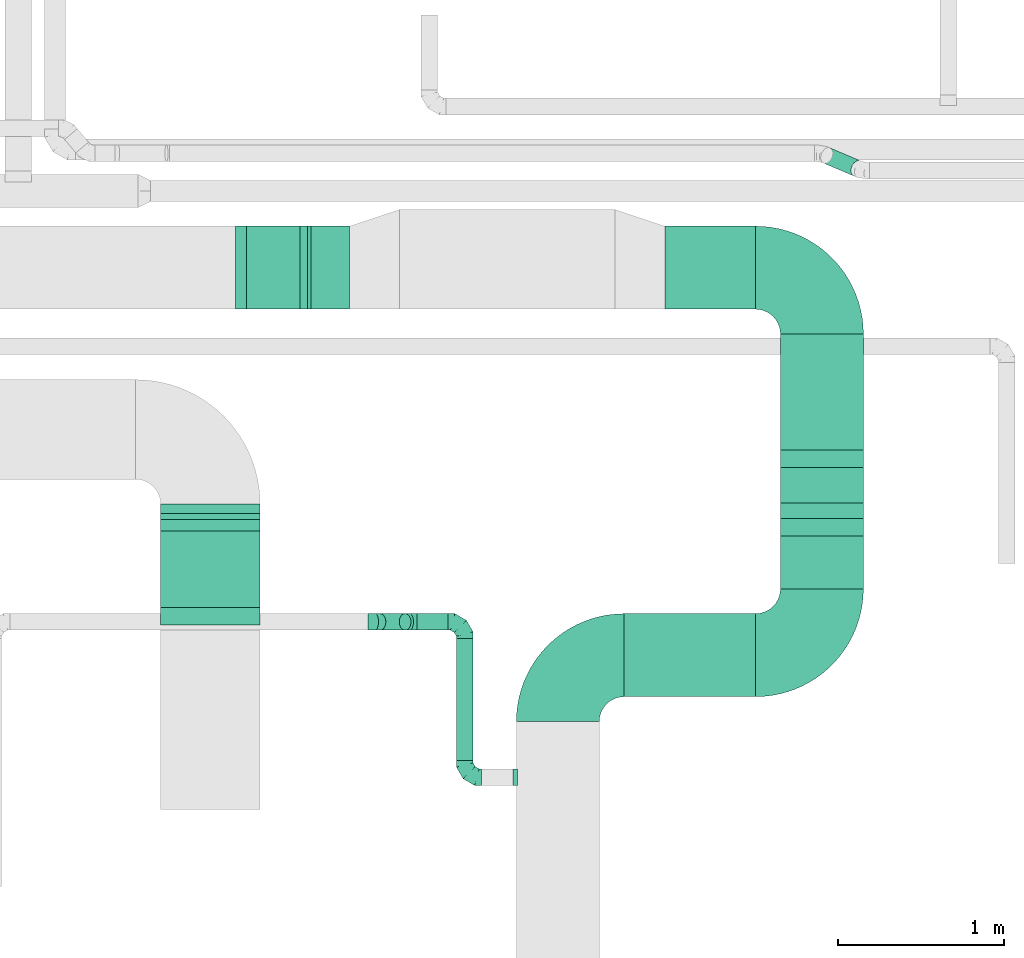
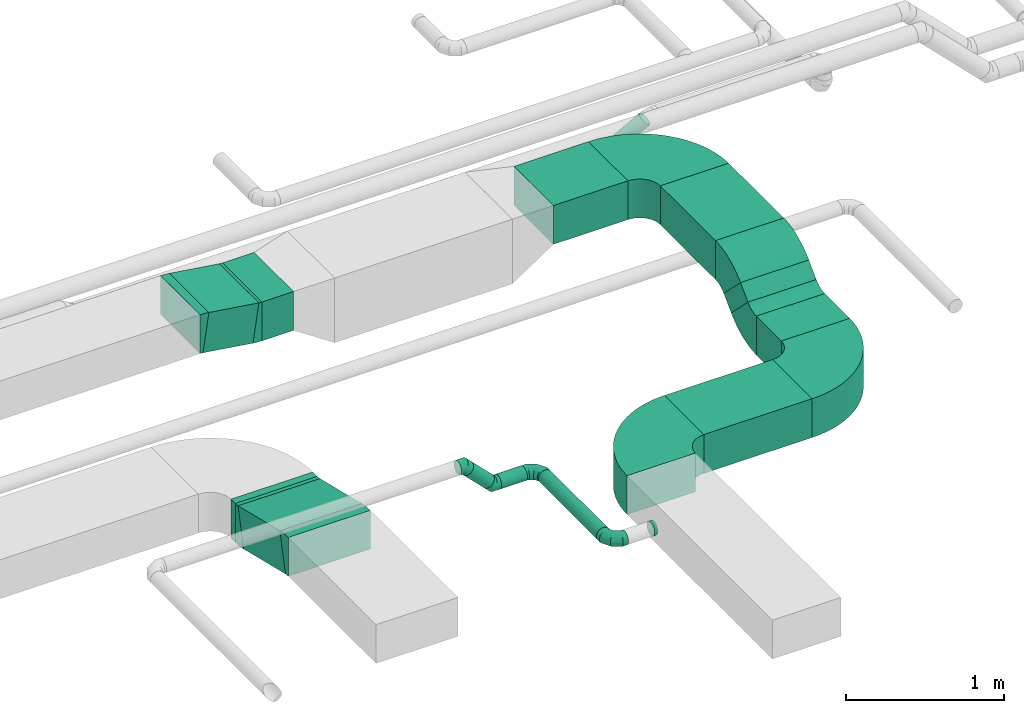
# One storey, part 49 of 60: 14 flow fittings, 13 flow segments.
"""IFC2X3 building model written with IfcOpenShell, lengths in millimetres."""

from ifc_helpers import new_model, entity, si_unit, converted_unit, derived_unit, direction, frame, frame_2d, origin, origin_2d_with_axis, place, context, subcontext, project, spatial, polyline, circle_curve, parameter, trimmed, segment, composite_curve, rectangle, circle, outline, extrude, faceted_brep, source, transform, mapped, material, type_object, type_shapes, element, save


model = new_model("IFC2X3")

# Units and contexts
model_context = context("Model", 3, precision=0.01, world=origin(), true_north=direction((6.12303176911189e-17, 1.0)))
body_context = subcontext(model_context, "Body", "Model", "MODEL_VIEW")
ifc_project = project(units=[si_unit("LENGTHUNIT", "METRE", prefix="MILLI"), si_unit("AREAUNIT", "SQUARE_METRE"), si_unit("VOLUMEUNIT", "CUBIC_METRE"), converted_unit("PLANEANGLEUNIT", "DEGREE", entity("IfcRatioMeasure", 0.0174532925199433), si_unit("PLANEANGLEUNIT", "RADIAN"), dimensions=[0, 0, 0, 0, 0, 0, 0]), si_unit("MASSUNIT", "GRAM", prefix="KILO"), derived_unit("MASSDENSITYUNIT", [(si_unit("MASSUNIT", "GRAM", prefix="KILO"), 1), (si_unit("LENGTHUNIT", "METRE"), -3)]), derived_unit("MOMENTOFINERTIAUNIT", [(si_unit("LENGTHUNIT", "METRE"), 4)]), si_unit("TIMEUNIT", "SECOND"), si_unit("FREQUENCYUNIT", "HERTZ"), si_unit("THERMODYNAMICTEMPERATUREUNIT", "DEGREE_CELSIUS"), derived_unit("THERMALTRANSMITTANCEUNIT", [(si_unit("MASSUNIT", "GRAM", prefix="KILO"), 1), (si_unit("THERMODYNAMICTEMPERATUREUNIT", "KELVIN"), -1), (si_unit("TIMEUNIT", "SECOND"), -3)]), derived_unit("VOLUMETRICFLOWRATEUNIT", [(si_unit("LENGTHUNIT", "METRE"), 3), (si_unit("TIMEUNIT", "SECOND"), -1)]), derived_unit("MASSFLOWRATEUNIT", [(si_unit("MASSUNIT", "GRAM", prefix="KILO"), 1), (si_unit("TIMEUNIT", "SECOND"), -1)]), derived_unit("ROTATIONALFREQUENCYUNIT", [(si_unit("TIMEUNIT", "SECOND"), -1)]), si_unit("ELECTRICCURRENTUNIT", "AMPERE"), si_unit("ELECTRICVOLTAGEUNIT", "VOLT"), si_unit("POWERUNIT", "WATT"), si_unit("FORCEUNIT", "NEWTON", prefix="KILO"), si_unit("ILLUMINANCEUNIT", "LUX"), si_unit("LUMINOUSFLUXUNIT", "LUMEN"), si_unit("LUMINOUSINTENSITYUNIT", "CANDELA"), derived_unit("USERDEFINED", [(si_unit("MASSUNIT", "GRAM", prefix="KILO"), -1), (si_unit("LENGTHUNIT", "METRE"), -2), (si_unit("TIMEUNIT", "SECOND"), 3), (si_unit("LUMINOUSFLUXUNIT", "LUMEN"), 1)]), derived_unit("LINEARVELOCITYUNIT", [(si_unit("LENGTHUNIT", "METRE"), 1), (si_unit("TIMEUNIT", "SECOND"), -1)]), si_unit("PRESSUREUNIT", "PASCAL"), derived_unit("USERDEFINED", [(si_unit("LENGTHUNIT", "METRE"), -2), (si_unit("MASSUNIT", "GRAM", prefix="KILO"), 1), (si_unit("TIMEUNIT", "SECOND"), -2)]), derived_unit("LINEARFORCEUNIT", [(si_unit("MASSUNIT", "GRAM", prefix="KILO"), 1), (si_unit("LENGTHUNIT", "METRE"), 1), (si_unit("TIMEUNIT", "SECOND"), -2), (si_unit("LENGTHUNIT", "METRE"), -1)]), derived_unit("PLANARFORCEUNIT", [(si_unit("MASSUNIT", "GRAM", prefix="KILO"), 1), (si_unit("LENGTHUNIT", "METRE"), 1), (si_unit("TIMEUNIT", "SECOND"), -2), (si_unit("LENGTHUNIT", "METRE"), -2)])], contexts=[model_context])

# Site, building, storey
site_placement = place(None, origin())
site = spatial("IfcSite", under=ifc_project, at=site_placement, CompositionType="ELEMENT")
building_placement = place(site_placement, origin())
building = spatial("IfcBuilding", under=site, at=building_placement, CompositionType="ELEMENT")
storey_placement = place(building_placement, frame((0.0, 0.0, 19800.0)))
storey = spatial("IfcBuildingStorey", under=building, at=storey_placement, CompositionType="ELEMENT", Elevation=19800.0)

# Flow segments
duct_segment_type_1 = type_object("IfcDuctSegmentType", PredefinedType="NOTDEFINED")
flow_segment_1_placement = place(storey_placement, frame((68175.49, 9113.95, 3420.0)))
element("IfcFlowSegment", 1, at=flow_segment_1_placement, inside=storey, type_object=duct_segment_type_1, context=body_context, shape_type="SweptSolid", body=[
    extrude(rectangle(XDim=545.857864376264, YDim=500.0, at=origin_2d_with_axis()), frame((272.93, 250.0, 0.0), z_axis=(0.0, 0.0, 1.0), x_axis=(-1.0, 0.0, 0.0)), (0.0, 0.0, 1.0), 300.000000000001),
])
flow_segment_2_placement = place(storey_placement, frame((67930.49, 6779.81, 3150.0)))
element("IfcFlowSegment", 2, at=flow_segment_2_placement, inside=storey, type_object=duct_segment_type_1, context=body_context, shape_type="SweptSolid", body=[
    extrude(rectangle(XDim=790.857864376312, YDim=500.0, at=origin_2d_with_axis()), frame((395.43, 250.0, 0.0), z_axis=(0.0, 0.0, 1.0), x_axis=(-1.0, 0.0, 0.0)), (0.0, 0.0, 1.0), 300.000000000001),
])
flow_segment_3_placement = place(storey_placement, frame((68871.35, 8265.48, 3420.0)))
element("IfcFlowSegment", 3, at=flow_segment_3_placement, inside=storey, type_object=duct_segment_type_1, context=body_context, shape_type="SweptSolid", body=[
    extrude(rectangle(XDim=698.472628134516, YDim=499.999999999999, at=origin_2d_with_axis()), frame((250.0, 349.24, 0.0), z_axis=(0.0, 0.0, 1.0), x_axis=(0.0, -1.0, 0.0)), (0.0, 0.0, 1.0), 300.000000000001),
])
flow_segment_4_placement = place(storey_placement, frame((68871.35, 7429.81, 3150.0)))
element("IfcFlowSegment", 4, at=flow_segment_4_placement, inside=storey, type_object=duct_segment_type_1, context=body_context, shape_type="SweptSolid", body=[
    extrude(rectangle(XDim=317.141367049098, YDim=499.999999999999, at=origin_2d_with_axis()), frame((250.0, 158.57, 0.0), z_axis=(0.0, 0.0, 1.0), x_axis=(0.0, 1.0, 0.0)), (0.0, 0.0, 1.0), 300.000000000001),
])
flow_segment_5_placement = place(storey_placement, frame((68871.35, 7853.02, 3281.8)))
element("IfcFlowSegment", 5, at=flow_segment_5_placement, inside=storey, type_object=duct_segment_type_1, context=body_context, shape_type="SweptSolid", body=[
    extrude(rectangle(XDim=299.999999999998, YDim=133.309536149783, at=frame_2d((0.0, 0.0), x_axis=(0.0, 1.0))), frame((0.0, 153.2, 153.2), z_axis=(1.0, 0.0, 0.0), x_axis=(0.0, 0.707106792500132, 0.707106769872963)), (0.0, 0.0, 1.0), 500.000000000008),
])
flow_segment_6_placement = place(storey_placement, frame((65137.69, 7246.84, 2937.54)))
element("IfcFlowSegment", 6, at=flow_segment_6_placement, inside=storey, type_object=duct_segment_type_1, context=body_context, shape_type="SweptSolid", body=[
    extrude(rectangle(XDim=300.000000000001, YDim=546.006755026433, at=frame_2d((0.0, 0.0), x_axis=(0.0, 1.0))), frame((0.0, 300.6, 209.93), z_axis=(1.0, 0.0, 0.0), x_axis=(0.0, -0.972018465382417, 0.234904454950542)), (0.0, 0.0, 1.0), 600.000000000002),
])
flow_segment_7_placement = place(storey_placement, frame((66043.25, 9113.95, 3420.0)))
element("IfcFlowSegment", 7, at=flow_segment_7_placement, inside=storey, type_object=duct_segment_type_1, context=body_context, shape_type="SweptSolid", body=[
    extrude(rectangle(XDim=232.243918103055, YDim=500.0, at=origin_2d_with_axis()), frame((116.12, 250.0, 0.0)), (0.0, 0.0, 1.0), 300.000000000001),
])
flow_segment_8_placement = place(storey_placement, frame((65612.18, 9113.95, 3424.76)))
element("IfcFlowSegment", 8, at=flow_segment_8_placement, inside=storey, type_object=duct_segment_type_1, context=body_context, shape_type="SweptSolid", body=[
    extrude(rectangle(XDim=300.000000000003, YDim=369.670729131551, at=frame_2d((0.0, 0.0), x_axis=(0.0, 1.0))), frame((204.65, 0.0, 175.24), z_axis=(0.0, 1.0, 0.0), x_axis=(-0.989413478216875, 0.0, 0.145123978455616)), (0.0, 0.0, 1.0), 500.000000000001),
])
flow_segment_9_placement = place(storey_placement, frame((65137.69, 7883.27, 2924.95)))
element("IfcFlowSegment", 9, at=flow_segment_9_placement, inside=storey, type_object=duct_segment_type_1, context=body_context, shape_type="SweptSolid", body=[
    extrude(rectangle(XDim=56.1804576160397, YDim=600.000000000002, at=origin_2d_with_axis()), frame((300.0, 28.09, 0.0), z_axis=(0.0, 0.0, 1.0), x_axis=(0.0, -1.0, 0.0)), (0.0, 0.0, 1.0), 300.000000000001),
])
duct_segment_type_2 = type_object("IfcDuctSegmentType", PredefinedType="NOTDEFINED")
flow_segment_10_placement = place(storey_placement, frame((66918.4, 6395.17, 3198.4)))
element("IfcFlowSegment", 10, at=flow_segment_10_placement, inside=storey, type_object=duct_segment_type_2, context=body_context, shape_type="SweptSolid", body=[
    extrude(circle(Radius=50.0, at=origin_2d_with_axis()), frame((51.6, 0.0, 51.6), z_axis=(0.0, 1.0, 0.0), x_axis=(1.0, 0.0, 0.0)), (0.0, 0.0, 1.0), 735.000000000014),
])
flow_segment_11_placement = place(storey_placement, frame((66422.34, 7178.57, 3242.34)))
element("IfcFlowSegment", 11, at=flow_segment_11_placement, inside=storey, type_object=duct_segment_type_2, context=body_context, shape_type="SweptSolid", body=[
    extrude(circle(Radius=50.0, at=origin_2d_with_axis()), frame((36.95, 51.6, 188.37), z_axis=(0.707106781186537, 0.0, -0.707106781186558), x_axis=(0.0, -1.0, 0.0)), (0.0, 0.0, 1.0), 214.142135623754),
])
flow_segment_12_placement = place(storey_placement, frame((66681.42, 7178.57, 3198.4)))
element("IfcFlowSegment", 12, at=flow_segment_12_placement, inside=storey, type_object=duct_segment_type_2, context=body_context, shape_type="SweptSolid", body=[
    extrude(circle(Radius=50.0, at=origin_2d_with_axis()), frame((0.0, 51.6, 51.6), z_axis=(1.0, 0.0, 0.0), x_axis=(0.0, 1.0, 0.0)), (0.0, 0.0, 1.0), 188.578643762706),
])
flow_segment_13_placement = place(storey_placement, frame((69112.12, 9912.36, 3249.0)))
element("IfcFlowSegment", 13, at=flow_segment_13_placement, inside=storey, type_object=duct_segment_type_2, context=body_context, shape_type="SweptSolid", body=[
    extrude(circle(Radius=50.0, at=origin_2d_with_axis()), frame((221.32, 49.47, 221.29), z_axis=(-0.677188394410879, 0.287805067624671, -0.677188394410872), x_axis=(0.0, 0.920330918458449, 0.391140640344912)), (0.0, 0.0, 1.0), 270.134206656777),
])

# Flow fittings
ifc_material = material()
duct_fitting_type_1 = type_object("IfcDuctFittingType", PredefinedType="NOTDEFINED", material=ifc_material)
shared_shape_1 = source(origin(), body_context, "Body", "Brep", [
    faceted_brep([(-100.0, 0.0, -50.0), (-100.0, -12.94, -48.3), (-100.0, -25.0, -43.3), (-100.0, -35.36, -35.36), (-100.0, -43.3, -25.0), (-100.0, -48.3, -12.94), (-100.0, -50.0, 0.0), (-100.0, -48.3, 12.94), (-100.0, -43.3, 25.0), (-100.0, -35.36, 35.36), (-100.0, -25.0, 43.3), (-100.0, -12.94, 48.3), (-100.0, 0.0, 50.0), (-100.0, 12.94, 48.3), (-100.0, 25.0, 43.3), (-100.0, 35.36, 35.36), (-100.0, 43.3, 25.0), (-100.0, 48.3, 12.94), (-100.0, 50.0, 0.0), (-100.0, 48.3, -12.94), (-100.0, 43.3, -25.0), (-100.0, 35.36, -35.36), (-100.0, 25.0, -43.3), (-100.0, 12.94, -48.3), (-76.67, 12.94, 48.3), (-79.9, 25.0, 43.3), (-73.21, 0.0, 50.0), (-82.68, 35.36, 35.36), (-86.15, 48.3, 12.94), (-86.6, 50.0, 0.0), (-84.81, 43.3, 25.0), (-84.81, 43.3, -25.0), (-82.68, 35.36, -35.36), (-86.15, 48.3, -12.94), (-76.67, 12.94, -48.3), (-73.21, 0.0, -50.0), (-79.9, 25.0, -43.3), (-69.74, -12.94, -48.3), (-66.51, -25.0, -43.3), (-63.73, -35.36, -35.36), (-61.6, -43.3, -25.0), (-60.26, -48.3, -12.94), (-59.81, -50.0, 0.0), (-60.26, -48.3, 12.94), (-61.6, -43.3, 25.0), (-63.73, -35.36, 35.36), (-66.51, -25.0, 43.3), (-69.74, -12.94, 48.3), (-36.27, 36.27, 48.3), (-45.1, 45.1, 43.3), (-26.79, 26.79, 50.0), (-52.68, 52.68, 35.36), (-58.49, 58.49, 25.0), (-62.15, 62.15, 12.94), (-63.4, 63.4, 0.0), (-62.15, 62.15, -12.94), (-58.49, 58.49, -25.0), (-52.68, 52.68, -35.36), (-36.27, 36.27, -48.3), (-26.79, 26.79, -50.0), (-45.1, 45.1, -43.3), (-17.32, 17.32, -48.3), (-8.49, 8.49, -43.3), (-0.91, 0.91, -35.36), (4.9, -4.9, -25.0), (8.56, -8.56, -12.94), (9.81, -9.81, 0.0), (8.56, -8.56, 12.94), (4.9, -4.9, 25.0), (-0.91, 0.91, 35.36), (-8.49, 8.49, 43.3), (-17.32, 17.32, 48.3), (-12.94, 76.67, 48.3), (-25.0, 79.9, 43.3), (0.0, 73.21, 50.0), (-35.36, 82.68, 35.36), (-43.3, 84.81, 25.0), (-48.3, 86.15, 12.94), (-50.0, 86.6, 0.0), (-48.3, 86.15, -12.94), (-43.3, 84.81, -25.0), (-35.36, 82.68, -35.36), (-12.94, 76.67, -48.3), (0.0, 73.21, -50.0), (-25.0, 79.9, -43.3), (12.94, 69.74, -48.3), (25.0, 66.51, -43.3), (35.36, 63.73, -35.36), (43.3, 61.6, -25.0), (48.3, 60.26, -12.94), (50.0, 59.81, 0.0), (48.3, 60.26, 12.94), (43.3, 61.6, 25.0), (35.36, 63.73, 35.36), (25.0, 66.51, 43.3), (12.94, 69.74, 48.3), (-12.94, 100.0, -48.3), (-25.0, 100.0, -43.3), (-35.36, 100.0, -35.36), (-43.3, 100.0, -25.0), (-48.3, 100.0, -12.94), (-50.0, 100.0, 0.0), (-48.3, 100.0, 12.94), (-43.3, 100.0, 25.0), (-35.36, 100.0, 35.36), (-25.0, 100.0, 43.3), (-12.94, 100.0, 48.3), (0.0, 100.0, 50.0), (12.94, 100.0, 48.3), (25.0, 100.0, 43.3), (35.36, 100.0, 35.36), (43.3, 100.0, 25.0), (48.3, 100.0, 12.94), (50.0, 100.0, 0.0), (48.3, 100.0, -12.94), (43.3, 100.0, -25.0), (35.36, 100.0, -35.36), (25.0, 100.0, -43.3), (12.94, 100.0, -48.3), (0.0, 100.0, -50.0)], [[[0, 1, 2, 3, 4, 5, 6, 7, 8, 9, 10, 11, 12, 13, 14, 15, 16, 17, 18, 19, 20, 21, 22, 23]], [[24, 25, 14, 13]], [[26, 24, 13, 12]], [[14, 25, 27, 15]], [[28, 29, 18, 17]], [[30, 28, 17, 16]], [[15, 27, 30, 16]], [[20, 31, 32, 21]], [[33, 31, 20, 19]], [[18, 29, 33, 19]], [[34, 35, 0, 23]], [[36, 34, 23, 22]], [[32, 36, 22, 21]], [[2, 1, 37, 38]], [[3, 2, 38, 39]], [[0, 35, 37, 1]], [[5, 4, 40, 41]], [[6, 5, 41, 42]], [[3, 39, 40, 4]], [[6, 42, 43, 7]], [[7, 43, 44, 8]], [[8, 44, 45, 9]], [[10, 46, 47, 11]], [[11, 47, 26, 12]], [[10, 9, 45, 46]], [[48, 49, 25, 24]], [[50, 48, 24, 26]], [[27, 25, 49, 51]], [[52, 53, 28, 30]], [[51, 52, 30, 27]], [[29, 28, 53, 54]], [[55, 56, 31, 33]], [[54, 55, 33, 29]], [[57, 32, 31, 56]], [[58, 59, 35, 34]], [[60, 58, 34, 36]], [[57, 60, 36, 32]], [[37, 35, 59, 61]], [[38, 37, 61, 62]], [[39, 38, 62, 63]], [[41, 40, 64, 65]], [[42, 41, 65, 66]], [[63, 64, 40, 39]], [[43, 42, 66, 67]], [[44, 43, 67, 68]], [[68, 69, 45, 44]], [[46, 45, 69, 70]], [[47, 46, 70, 71]], [[26, 47, 71, 50]], [[72, 73, 49, 48]], [[74, 72, 48, 50]], [[51, 49, 73, 75]], [[76, 77, 53, 52]], [[75, 76, 52, 51]], [[54, 53, 77, 78]], [[79, 80, 56, 55]], [[78, 79, 55, 54]], [[81, 57, 56, 80]], [[82, 83, 59, 58]], [[84, 82, 58, 60]], [[81, 84, 60, 57]], [[61, 59, 83, 85]], [[62, 61, 85, 86]], [[63, 62, 86, 87]], [[65, 64, 88, 89]], [[66, 65, 89, 90]], [[87, 88, 64, 63]], [[67, 66, 90, 91]], [[68, 67, 91, 92]], [[92, 93, 69, 68]], [[70, 69, 93, 94]], [[71, 70, 94, 95]], [[50, 71, 95, 74]], [[96, 97, 98, 99, 100, 101, 102, 103, 104, 105, 106, 107, 108, 109, 110, 111, 112, 113, 114, 115, 116, 117, 118, 119]], [[72, 74, 107, 106]], [[73, 72, 106, 105]], [[75, 73, 105, 104]], [[77, 76, 103, 102]], [[78, 77, 102, 101]], [[75, 104, 103, 76]], [[78, 101, 100, 79]], [[79, 100, 99, 80]], [[80, 99, 98, 81]], [[96, 119, 83, 82]], [[97, 96, 82, 84]], [[84, 81, 98, 97]], [[83, 119, 118, 85]], [[85, 118, 117, 86]], [[86, 117, 116, 87]], [[88, 115, 114, 89]], [[89, 114, 113, 90]], [[87, 116, 115, 88]], [[91, 90, 113, 112]], [[92, 91, 112, 111]], [[93, 92, 111, 110]], [[95, 94, 109, 108]], [[74, 95, 108, 107]], [[110, 109, 94, 93]]]),
])
type_shapes(duct_fitting_type_1, [shared_shape_1])
for number, where, z_axis, x_axis in (
    (14, (66970.0, 6295.17, 3250.0), (0.0, 0.0, 1.0), (0.0, -1.0, 0.0)),
    (15, (66970.0, 7230.17, 3250.0), (0.0, 0.0, 1.0), (0.0, 1.0, 0.0)),
):
    element("IfcFlowFitting", number, at=place(storey_placement, frame(where, z_axis=z_axis, x_axis=x_axis)), inside=storey, type_object=duct_fitting_type_1, material=ifc_material, context=body_context, shape_type="MappedRepresentation", body=[
        mapped(shared_shape_1, transform((0.0, 0.0, 0.0), scale=1.0)),
    ])
duct_fitting_type_2 = type_object("IfcDuctFittingType", PredefinedType="NOTDEFINED", material=ifc_material)
shared_shape_2 = source(origin(), body_context, "Body", "Brep", [
    faceted_brep([(-41.42, 0.0, -50.0), (-41.42, -12.94, -48.3), (-41.42, -25.0, -43.3), (-41.42, -35.36, -35.36), (-41.42, -43.3, -25.0), (-41.42, -48.3, -12.94), (-41.42, -50.0, 0.0), (-41.42, -48.3, 12.94), (-41.42, -43.3, 25.0), (-41.42, -35.36, 35.36), (-41.42, -25.0, 43.3), (-41.42, -12.94, 48.3), (-41.42, 0.0, 50.0), (-41.42, 12.94, 48.3), (-41.42, 25.0, 43.3), (-41.42, 35.36, 35.36), (-41.42, 43.3, 25.0), (-41.42, 48.3, 12.94), (-41.42, 50.0, 0.0), (-41.42, 48.3, -12.94), (-41.42, 43.3, -25.0), (-41.42, 35.36, -35.36), (-41.42, 25.0, -43.3), (-41.42, 12.94, -48.3), (-5.36, 12.94, 48.3), (-10.36, 25.0, 43.3), (0.0, 0.0, 50.0), (-14.64, 35.36, 35.36), (-20.0, 48.3, 12.94), (-20.71, 50.0, 0.0), (-17.94, 43.3, 25.0), (-17.94, 43.3, -25.0), (-14.64, 35.36, -35.36), (-20.0, 48.3, -12.94), (-5.36, 12.94, -48.3), (0.0, 0.0, -50.0), (-10.36, 25.0, -43.3), (5.36, -12.94, -48.3), (10.36, -25.0, -43.3), (14.64, -35.36, -35.36), (17.94, -43.3, -25.0), (20.0, -48.3, -12.94), (20.71, -50.0, 0.0), (20.0, -48.3, 12.94), (17.94, -43.3, 25.0), (14.64, -35.36, 35.36), (10.36, -25.0, 43.3), (5.36, -12.94, 48.3), (29.29, 29.29, 50.0), (20.14, 38.44, 48.3), (11.61, 46.97, 43.3), (4.29, 54.29, 35.36), (-1.33, 59.91, 25.0), (-4.86, 63.44, 12.94), (-6.07, 64.64, 0.0), (-4.86, 63.44, -12.94), (-1.33, 59.91, -25.0), (4.29, 54.29, -35.36), (11.61, 46.97, -43.3), (20.14, 38.44, -48.3), (29.29, 29.29, -50.0), (38.44, 20.14, -48.3), (46.97, 11.61, -43.3), (54.29, 4.29, -35.36), (59.91, -1.33, -25.0), (63.44, -4.86, -12.94), (64.64, -6.07, 0.0), (63.44, -4.86, 12.94), (59.91, -1.33, 25.0), (54.29, 4.29, 35.36), (46.97, 11.61, 43.3), (38.44, 20.14, 48.3)], [[[0, 1, 2, 3, 4, 5, 6, 7, 8, 9, 10, 11, 12, 13, 14, 15, 16, 17, 18, 19, 20, 21, 22, 23]], [[24, 25, 14, 13]], [[26, 24, 13, 12]], [[14, 25, 27, 15]], [[28, 29, 18, 17]], [[30, 28, 17, 16]], [[16, 15, 27, 30]], [[20, 31, 32, 21]], [[33, 31, 20, 19]], [[18, 29, 33, 19]], [[34, 35, 0, 23]], [[36, 34, 23, 22]], [[32, 36, 22, 21]], [[1, 0, 35, 37]], [[2, 1, 37, 38]], [[38, 39, 3, 2]], [[5, 4, 40, 41]], [[6, 5, 41, 42]], [[39, 40, 4, 3]], [[6, 42, 43, 7]], [[7, 43, 44, 8]], [[8, 44, 45, 9]], [[9, 45, 46, 10]], [[10, 46, 47, 11]], [[26, 12, 11, 47]], [[24, 26, 48, 49]], [[25, 24, 49, 50]], [[27, 25, 50, 51]], [[28, 30, 52, 53]], [[29, 28, 53, 54]], [[27, 51, 52, 30]], [[29, 54, 55, 33]], [[33, 55, 56, 31]], [[31, 56, 57, 32]], [[36, 58, 59, 34]], [[34, 59, 60, 35]], [[36, 32, 57, 58]], [[61, 62, 38, 37]], [[60, 61, 37, 35]], [[63, 39, 38, 62]], [[40, 64, 65, 41]], [[41, 65, 66, 42]], [[64, 40, 39, 63]], [[43, 42, 66, 67]], [[44, 43, 67, 68]], [[68, 69, 45, 44]], [[47, 46, 70, 71]], [[26, 47, 71, 48]], [[69, 70, 46, 45]], [[59, 58, 57, 56, 55, 54, 53, 52, 51, 50, 49, 48, 71, 70, 69, 68, 67, 66, 65, 64, 63, 62, 61, 60]]]),
])
type_shapes(duct_fitting_type_2, [shared_shape_2])
for number, where, z_axis, x_axis in (
    (16, (66430.0, 7230.17, 3460.0), (0.0, 1.0, 0.0), (1.0, 0.0, 0.0)),
    (17, (66640.0, 7230.17, 3250.0), (0.0, -1.0, 0.0), (0.707106781186487, 0.0, -0.707106781186608)),
):
    element("IfcFlowFitting", number, at=place(storey_placement, frame(where, z_axis=z_axis, x_axis=x_axis)), inside=storey, type_object=duct_fitting_type_2, material=ifc_material, context=body_context, shape_type="MappedRepresentation", body=[
        mapped(shared_shape_2, transform((0.0, 0.0, 0.0), scale=1.0)),
    ])
duct_fitting_type_3 = type_object("IfcDuctFittingType", PredefinedType="NOTDEFINED", material=ifc_material)
shared_shape_3 = source(origin(), body_context, "Body", "Brep", [
    faceted_brep([(20.0, 12.94, -48.3), (20.0, 25.0, -43.3), (20.0, 35.36, -35.36), (20.0, 43.3, -25.0), (20.0, 48.3, -12.94), (20.0, 50.0, 0.0), (20.0, 48.3, 12.94), (20.0, 43.3, 25.0), (20.0, 35.36, 35.36), (20.0, 25.0, 43.3), (20.0, 12.94, 48.3), (20.0, 0.0, 50.0), (20.0, -12.94, 48.3), (20.0, -25.0, 43.3), (20.0, -35.36, 35.36), (20.0, -43.3, 25.0), (20.0, -48.3, 12.94), (20.0, -50.0, 0.0), (20.0, -48.3, -12.94), (20.0, -43.3, -25.0), (20.0, -35.36, -35.36), (20.0, -25.0, -43.3), (20.0, -12.94, -48.3), (20.0, 0.0, -50.0), (0.0, 0.0, 50.0), (0.0, 12.94, 48.3), (-6.1, 12.94, 48.3), (-6.1, 0.0, 50.0), (0.0, 25.0, 43.3), (-6.1, 25.0, 43.3), (0.0, 35.36, 35.36), (-6.1, 35.36, 35.36), (0.0, 43.3, 25.0), (0.0, 48.3, 12.94), (-6.1, 48.3, 12.94), (-6.1, 43.3, 25.0), (0.0, 50.0, 0.0), (-6.1, 50.0, 0.0), (0.0, 48.3, -12.94), (-6.1, 48.3, -12.94), (0.0, 43.3, -25.0), (-6.1, 43.3, -25.0), (0.0, 35.36, -35.36), (-6.1, 35.36, -35.36), (0.0, 25.0, -43.3), (0.0, 12.94, -48.3), (-6.1, 12.94, -48.3), (-6.1, 25.0, -43.3), (0.0, 0.0, -50.0), (-6.1, 0.0, -50.0), (0.0, -12.94, -48.3), (-6.1, -12.94, -48.3), (0.0, -25.0, -43.3), (-6.1, -25.0, -43.3), (0.0, -35.36, -35.36), (-6.1, -35.36, -35.36), (0.0, -43.3, -25.0), (0.0, -48.3, -12.94), (-6.1, -48.3, -12.94), (-6.1, -43.3, -25.0), (0.0, -50.0, 0.0), (-6.1, -50.0, 0.0), (0.0, -48.3, 12.94), (-6.1, -48.3, 12.94), (0.0, -43.3, 25.0), (-6.1, -43.3, 25.0), (0.0, -35.36, 35.36), (-6.1, -35.36, 35.36), (0.0, -25.0, 43.3), (0.0, -12.94, 48.3), (-6.1, -12.94, 48.3), (-6.1, -25.0, 43.3)], [[[0, 1, 2, 3, 4, 5, 6, 7, 8, 9, 10, 11, 12, 13, 14, 15, 16, 17, 18, 19, 20, 21, 22, 23]], [[24, 11, 10, 25, 26, 27]], [[25, 10, 9, 28, 29, 26]], [[28, 9, 8, 30, 31, 29]], [[32, 7, 6, 33, 34, 35]], [[33, 6, 5, 36, 37, 34]], [[30, 8, 7, 32, 35, 31]], [[36, 5, 4, 38, 39, 37]], [[38, 4, 3, 40, 41, 39]], [[40, 3, 2, 42, 43, 41]], [[44, 1, 0, 45, 46, 47]], [[45, 0, 23, 48, 49, 46]], [[42, 2, 1, 44, 47, 43]], [[48, 23, 22, 50, 51, 49]], [[50, 22, 21, 52, 53, 51]], [[52, 21, 20, 54, 55, 53]], [[56, 19, 18, 57, 58, 59]], [[57, 18, 17, 60, 61, 58]], [[54, 20, 19, 56, 59, 55]], [[60, 17, 16, 62, 63, 61]], [[62, 16, 15, 64, 65, 63]], [[64, 15, 14, 66, 67, 65]], [[68, 13, 12, 69, 70, 71]], [[69, 12, 11, 24, 27, 70]], [[66, 14, 13, 68, 71, 67]], [[49, 51, 53, 55, 59, 58, 61, 63, 65, 67, 71, 70, 27, 26, 29, 31, 35, 34, 37, 39, 41, 43, 47, 46]]]),
])
type_shapes(duct_fitting_type_3, [shared_shape_3])
flow_fitting_1_placement = place(storey_placement, frame((67280.49, 6295.17, 3250.0), z_axis=(0.0, 0.0, -1.0), x_axis=(-1.0, 0.0, 0.0)))
element("IfcFlowFitting", 18, at=flow_fitting_1_placement, inside=storey, type_object=duct_fitting_type_3, material=ifc_material, context=body_context, shape_type="MappedRepresentation", body=[
    mapped(shared_shape_3, transform((0.0, 0.0, 0.0), scale=1.0)),
])
duct_fitting_type_4 = type_object("IfcDuctFittingType", PredefinedType="NOTDEFINED", material=ifc_material)
shared_shape_4 = source(origin(), body_context, "Body", "SweptSolid", [
    extrude(outline(composite_curve([segment(polyline([(-450.0, -200.0), (50.0, -200.0)]), True, "CONTINUOUS"), segment(trimmed(circle_curve(frame_2d((200.0, -200.0), x_axis=(0.0, 1.0)), 150.0), [parameter(0.0)], [parameter(90.0000000000001)], True, "PARAMETER"), False, "CONTINUOUS"), segment(polyline([(200.0, -50.0), (200.0, 450.0)]), True, "CONTINUOUS"), segment(trimmed(circle_curve(frame_2d((200.0, -200.0), x_axis=(0.0, 1.0)), 650.0), [parameter(0.0)], [parameter(90.0000000000001)], True, "PARAMETER"), True, "CONTINUOUS")], self_intersect=False)), frame((-200.0, 200.0, -150.0), z_axis=(0.0, 0.0, 1.0), x_axis=(-1.0, 0.0, 0.0)), (0.0, 0.0, 1.0), 300.0),
])
type_shapes(duct_fitting_type_4, [shared_shape_4])
flow_fitting_2_placement = place(storey_placement, frame((67530.49, 7029.81, 3300.0), z_axis=(0.0, 0.0, 1.0), x_axis=(-1.0, 0.0, 0.0)))
element("IfcFlowFitting", 19, at=flow_fitting_2_placement, inside=storey, type_object=duct_fitting_type_4, material=ifc_material, context=body_context, shape_type="MappedRepresentation", body=[
    mapped(shared_shape_4, transform((0.0, 0.0, 0.0), scale=1.0)),
])
flow_fitting_3_placement = place(storey_placement, frame((69121.35, 7029.81, 3300.0)))
element("IfcFlowFitting", 20, at=flow_fitting_3_placement, inside=storey, type_object=duct_fitting_type_4, material=ifc_material, context=body_context, shape_type="MappedRepresentation", body=[
    mapped(shared_shape_4, transform((0.0, 0.0, 0.0), scale=1.0)),
])
flow_fitting_4_placement = place(storey_placement, frame((69121.35, 9363.95, 3570.0), z_axis=(0.0, 0.0, 1.0), x_axis=(0.0, 1.0, 0.0)))
element("IfcFlowFitting", 21, at=flow_fitting_4_placement, inside=storey, type_object=duct_fitting_type_4, material=ifc_material, context=body_context, shape_type="MappedRepresentation", body=[
    mapped(shared_shape_4, transform((0.0, 0.0, 0.0), scale=1.0)),
])
duct_fitting_type_5 = type_object("IfcDuctFittingType", PredefinedType="NOTDEFINED", material=ifc_material)
shared_shape_5 = source(origin(), body_context, "Body", "SweptSolid", [
    extrude(outline(composite_curve([segment(polyline([(-193.93, -106.07), (106.07, -106.07)]), True, "CONTINUOUS"), segment(trimmed(circle_curve(frame_2d((256.07, -106.07), x_axis=(-0.707106792500255, 0.707106769872837)), 150.0), [parameter(0.0)], [parameter(44.9999990832676)], True, "PARAMETER"), False, "CONTINUOUS"), segment(polyline([(150.0, 0.0), (-62.13, 212.13)]), True, "CONTINUOUS"), segment(trimmed(circle_curve(frame_2d((256.07, -106.07), x_axis=(-0.707106792500255, 0.707106769872837)), 450.0), [parameter(0.0)], [parameter(44.9999990832676)], True, "PARAMETER"), True, "CONTINUOUS")], self_intersect=False)), frame((-18.2, 43.93, -250.0), z_axis=(0.0, 0.0, 1.0), x_axis=(-0.70710676987284, 0.707106792500255, 0.0)), (0.0, 0.0, 1.0), 500.0),
])
type_shapes(duct_fitting_type_5, [shared_shape_5])
for number, where, z_axis, x_axis in (
    (22, (69121.35, 7871.22, 3300.0), (1.0, 0.0, 0.0), (0.0, 1.0, 0.0)),
    (23, (69121.35, 8141.22, 3570.0), (-1.0, 0.0, 0.0), (0.0, 0.707106792500201, 0.707106769872894)),
):
    element("IfcFlowFitting", number, at=place(storey_placement, frame(where, z_axis=z_axis, x_axis=x_axis)), inside=storey, type_object=duct_fitting_type_5, material=ifc_material, context=body_context, shape_type="MappedRepresentation", body=[
        mapped(shared_shape_5, transform((0.0, 0.0, 0.0), scale=1.0)),
    ])
duct_fitting_type_6 = type_object("IfcDuctFittingType", PredefinedType="NOTDEFINED", material=ifc_material)
shared_shape_6 = source(origin(), body_context, "Body", "SweptSolid", [
    extrude(outline(composite_curve([segment(polyline([(-154.2, -35.24), (145.8, -35.24)]), True, "CONTINUOUS"), segment(trimmed(circle_curve(frame_2d((295.8, -35.24), x_axis=(-0.972018465382432, 0.23490445495048)), 150.0), [parameter(0.0)], [parameter(13.5859907892513)], True, "PARAMETER"), False, "CONTINUOUS"), segment(polyline([(150.0, 0.0), (-141.61, 70.47)]), True, "CONTINUOUS"), segment(trimmed(circle_curve(frame_2d((295.8, -35.24), x_axis=(-0.972018465382432, 0.23490445495048)), 450.0), [parameter(0.0)], [parameter(13.5859907892513)], True, "PARAMETER"), True, "CONTINUOUS")], self_intersect=False)), frame((-0.5, 4.2, -300.0), z_axis=(0.0, 0.0, 1.0), x_axis=(-0.234904454950481, 0.972018465382432, 0.0)), (0.0, 0.0, 1.0), 600.0),
])
type_shapes(duct_fitting_type_6, [shared_shape_6])
for number, where, z_axis, x_axis in (
    (24, (65437.69, 7247.34, 3220.0), (1.0, 0.0, 0.0), (0.0, -0.972018465382428, 0.234904454950498)),
    (25, (65437.69, 7847.54, 3074.95), (1.0, 0.0, 0.0), (0.0, 0.972018465382421, -0.234904454950525)),
):
    element("IfcFlowFitting", number, at=place(storey_placement, frame(where, z_axis=z_axis, x_axis=x_axis)), inside=storey, type_object=duct_fitting_type_6, material=ifc_material, context=body_context, shape_type="MappedRepresentation", body=[
        mapped(shared_shape_6, transform((0.0, 0.0, 0.0), scale=1.0)),
    ])
duct_fitting_type_7 = type_object("IfcDuctFittingType", PredefinedType="NOTDEFINED", material=ifc_material)
shared_shape_7 = source(origin(), body_context, "Body", "SweptSolid", [
    extrude(outline(composite_curve([segment(polyline([(-151.59, -21.77), (148.41, -21.77)]), True, "CONTINUOUS"), segment(trimmed(circle_curve(frame_2d((298.41, -21.77), x_axis=(-0.989413478216883, 0.145123978455562)), 150.0), [parameter(0.0)], [parameter(8.34445857058201)], True, "PARAMETER"), False, "CONTINUOUS"), segment(polyline([(150.0, 0.0), (-146.82, 43.54)]), True, "CONTINUOUS"), segment(trimmed(circle_curve(frame_2d((298.41, -21.77), x_axis=(-0.989413478216883, 0.145123978455562)), 450.0), [parameter(0.0)], [parameter(8.34445857058201)], True, "PARAMETER"), True, "CONTINUOUS")], self_intersect=False)), frame((-0.12, 1.59, -250.0), z_axis=(0.0, 0.0, 1.0), x_axis=(-0.145123978455563, 0.989413478216883, 0.0)), (0.0, 0.0, 1.0), 500.0),
])
type_shapes(duct_fitting_type_7, [shared_shape_7])
for number, where, z_axis, x_axis in (
    (26, (65612.3, 9363.95, 3630.0), (0.0, 1.0, 0.0), (1.0, 0.0, 0.0)),
    (27, (66021.36, 9363.95, 3570.0), (0.0, -1.0, 0.0), (0.989413478216875, 0.0, -0.145123978455616)),
):
    element("IfcFlowFitting", number, at=place(storey_placement, frame(where, z_axis=z_axis, x_axis=x_axis)), inside=storey, type_object=duct_fitting_type_7, material=ifc_material, context=body_context, shape_type="MappedRepresentation", body=[
        mapped(shared_shape_7, transform((0.0, 0.0, 0.0), scale=1.0)),
    ])

save(model, "model.ifc")
